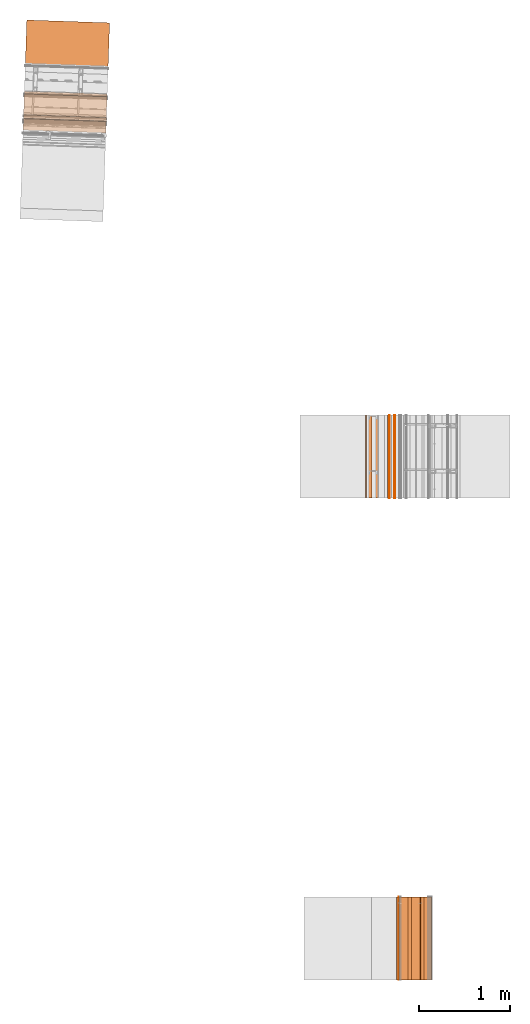
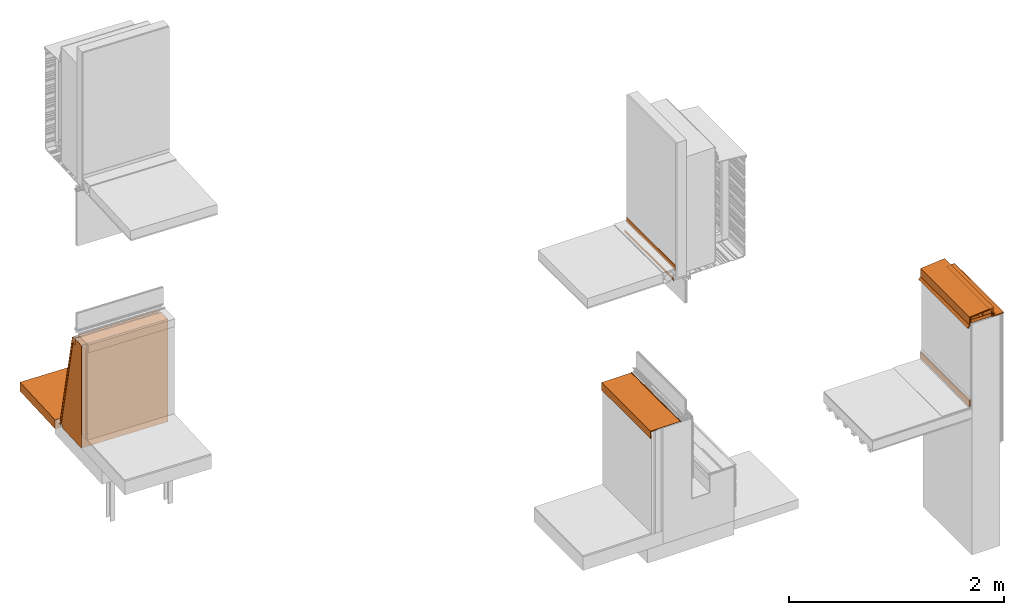
# One storey, part 3 of 36: 18 proxies.
"""IFC2X3 building model written with IfcOpenShell, lengths in feet."""

from ifc_helpers import new_model, entity, si_unit, converted_unit, derived_unit, direction, frame, frame_2d, origin, origin_2d_with_axis, place, context, subcontext, project, spatial, polyline, circle_curve, parameter, trimmed, segment, composite_curve, rectangle, outline, extrude, source, transform, mapped, material, type_object, type_shapes, element, save


model = new_model("IFC2X3")

# Units and contexts
model_context = context("Model", 3, precision=0.0001, world=origin(), true_north=direction((6.12303176911189e-17, 1.0)))
body_context = subcontext(model_context, "Body", "Model", "MODEL_VIEW")
ifc_project = project(units=[converted_unit("LENGTHUNIT", "FOOT", entity("IfcRatioMeasure", 0.3048), si_unit("LENGTHUNIT", "METRE"), dimensions=[1, 0, 0, 0, 0, 0, 0]), converted_unit("AREAUNIT", "SQUARE FOOT", entity("IfcRatioMeasure", 0.09290304), si_unit("AREAUNIT", "SQUARE_METRE"), dimensions=[2, 0, 0, 0, 0, 0, 0]), converted_unit("VOLUMEUNIT", "CUBIC FOOT", entity("IfcRatioMeasure", 0.028316846592), si_unit("VOLUMEUNIT", "CUBIC_METRE"), dimensions=[3, 0, 0, 0, 0, 0, 0]), converted_unit("PLANEANGLEUNIT", "DEGREE", entity("IfcRatioMeasure", 0.0174532925199433), si_unit("PLANEANGLEUNIT", "RADIAN"), dimensions=[0, 0, 0, 0, 0, 0, 0]), si_unit("MASSUNIT", "GRAM", prefix="KILO"), derived_unit("MASSDENSITYUNIT", [(si_unit("MASSUNIT", "GRAM", prefix="KILO"), 1), (si_unit("LENGTHUNIT", "METRE"), -3)]), si_unit("TIMEUNIT", "SECOND"), si_unit("FREQUENCYUNIT", "HERTZ"), si_unit("THERMODYNAMICTEMPERATUREUNIT", "DEGREE_CELSIUS"), derived_unit("THERMALTRANSMITTANCEUNIT", [(si_unit("MASSUNIT", "GRAM", prefix="KILO"), 1), (si_unit("THERMODYNAMICTEMPERATUREUNIT", "KELVIN"), -1), (si_unit("TIMEUNIT", "SECOND"), -3)]), derived_unit("VOLUMETRICFLOWRATEUNIT", [(si_unit("LENGTHUNIT", "METRE"), 3), (si_unit("TIMEUNIT", "SECOND"), -1)]), si_unit("ELECTRICCURRENTUNIT", "AMPERE"), si_unit("ELECTRICVOLTAGEUNIT", "VOLT"), si_unit("POWERUNIT", "WATT"), si_unit("FORCEUNIT", "NEWTON"), si_unit("ILLUMINANCEUNIT", "LUX"), si_unit("LUMINOUSFLUXUNIT", "LUMEN"), si_unit("LUMINOUSINTENSITYUNIT", "CANDELA"), derived_unit("USERDEFINED", [(si_unit("MASSUNIT", "GRAM", prefix="KILO"), -1), (si_unit("LENGTHUNIT", "METRE"), -2), (si_unit("TIMEUNIT", "SECOND"), 3), (si_unit("LUMINOUSFLUXUNIT", "LUMEN"), 1)]), derived_unit("LINEARVELOCITYUNIT", [(si_unit("LENGTHUNIT", "METRE"), 1), (si_unit("TIMEUNIT", "SECOND"), -1)]), si_unit("PRESSUREUNIT", "PASCAL"), derived_unit("USERDEFINED", [(si_unit("LENGTHUNIT", "METRE"), -2), (si_unit("MASSUNIT", "GRAM", prefix="KILO"), 1), (si_unit("TIMEUNIT", "SECOND"), -2)])], contexts=[model_context])

# Site, building, storey
site_placement = place(None, origin())
site = spatial("IfcSite", under=ifc_project, at=site_placement, CompositionType="ELEMENT")
building_placement = place(site_placement, origin())
building = spatial("IfcBuilding", under=site, at=building_placement, CompositionType="ELEMENT")
storey_placement = place(building_placement, origin())
storey = spatial("IfcBuildingStorey", under=building, at=storey_placement, Name="Level 1", CompositionType="ELEMENT", Elevation=0.0)

# Proxies
ifc_material_1 = material(Name="_EXISTING CAST-IN-PLACE CONCRETE")
building_element_proxy_type_1 = type_object("IfcBuildingElementProxyType", PredefinedType="NOTDEFINED", material=ifc_material_1)
shared_shape_1 = source(origin(), body_context, "Body", "SweptSolid", [
    extrude(rectangle(XDim=0.726514148720483, YDim=2.99999999999999, at=frame_2d((7.105427357601e-15, 7.105427357601e-15), x_axis=(1.0, 0.0))), frame((123.703824125935, -80.1652000961286, 18.5413868705315)), (0.0, 0.0, 1.0), 0.125),
])
type_shapes(building_element_proxy_type_1, [shared_shape_1])
proxy_1_placement = place(storey_placement, origin())
element("IfcBuildingElementProxy", 1, at=proxy_1_placement, inside=storey, type_object=building_element_proxy_type_1, material=ifc_material_1, context=body_context, shape_type="MappedRepresentation", body=[
    mapped(shared_shape_1, transform((0.0, 0.0, 0.0), scale=1.0)),
])
ifc_material_2 = material()
building_element_proxy_type_2 = type_object("IfcBuildingElementProxyType", PredefinedType="NOTDEFINED", material=ifc_material_2)
shared_shape_2 = source(origin(), body_context, "Body", "SweptSolid", [
    extrude(outline(composite_curve([segment(polyline([(-0.126157407405415, -0.0601851851839292), (-0.126157407400868, 0.148148148147087)]), True, "CONTINUOUS"), segment(trimmed(circle_curve(frame_2d((-0.136574074067539, 0.148148148147087), x_axis=(1.0, 0.0)), 0.0104166666666667), [parameter(0.0)], [parameter(90.0000000000001)], True, "PARAMETER"), True, "CONTINUOUS"), segment(polyline([(-0.136574074067539, 0.158564814815087), (-0.146990740738744, 0.158564814815087)]), True, "CONTINUOUS"), segment(polyline([(-0.146990740738744, 0.158564814815087), (-0.146990740738744, -0.0914351851849098)]), True, "CONTINUOUS"), segment(polyline([(-0.146990740738744, -0.0914351851849098), (0.269675925927928, -0.0914351851849098)]), True, "CONTINUOUS"), segment(polyline([(0.269675925927928, -0.0914351851849098), (0.269675925922996, -0.081018518519123)]), True, "CONTINUOUS"), segment(trimmed(circle_curve(frame_2d((0.259259259256325, -0.081018518519123), x_axis=(1.0, 0.0)), 0.0104166666666667), [parameter(0.0)], [parameter(90.0000000000001)], True, "PARAMETER"), True, "CONTINUOUS"), segment(polyline([(0.259259259256325, -0.0706018518515741), (-0.115740740747256, -0.0706018518505971)]), True, "CONTINUOUS"), segment(trimmed(circle_curve(frame_2d((-0.115740740747256, -0.0601851851839292), x_axis=(1.0, 0.0)), 0.0104166666666667), [parameter(180.0)], [parameter(270.0)], True, "PARAMETER"), False, "CONTINUOUS")], self_intersect=False)), frame((124.236045845562, -81.6735334294619, 18.6254931215366), z_axis=(0.0, -1.0, 0.0), x_axis=(1.0, 0.0, 0.0)), (0.0, 0.0, -1.0), 3.00833333333334),
])
type_shapes(building_element_proxy_type_2, [shared_shape_2])
proxy_2_placement = place(storey_placement, origin())
element("IfcBuildingElementProxy", 2, at=proxy_2_placement, inside=storey, type_object=building_element_proxy_type_2, material=ifc_material_2, context=body_context, shape_type="MappedRepresentation", body=[
    mapped(shared_shape_2, transform((0.0, 0.0, 0.0), scale=1.0)),
])
ifc_material_3 = material(Name="SHEET METAL COPING")
building_element_proxy_type_3 = type_object("IfcBuildingElementProxyType", PredefinedType="NOTDEFINED", material=ifc_material_3)
shared_shape_3 = source(origin(), body_context, "Body", "SweptSolid", [
    extrude(outline(polyline([(-0.384540585007616, -0.18030977257429), (0.420447563981819, -0.18030977257429), (0.405015562693536, -0.0039211907162079), (0.450069128128935, 0.0497715577507781), (0.446079313319709, 0.0531194098856544), (0.399639022126757, -0.0022259739848406), (0.41476366553856, -0.175101439239162), (-0.379768026807792, -0.175101439243266), (-0.406113571382451, 0.126029513184232), (-0.475565080766948, 0.184306249093279), (-0.478912932901812, 0.180316434284072), (-0.411114058922567, 0.123426424134038), (-0.384540585007616, -0.18030977257429)])), frame((123.718526042381, -81.6652000961286, 18.6189985999881), z_axis=(0.0, 1.0, 0.0), x_axis=(0.996194698091605, 0.0, 0.0871557427492606)), (0.0, 0.0, 1.0), 2.99999999999999),
])
type_shapes(building_element_proxy_type_3, [shared_shape_3])
proxy_3_placement = place(storey_placement, origin())
element("IfcBuildingElementProxy", 3, at=proxy_3_placement, inside=storey, type_object=building_element_proxy_type_3, material=ifc_material_3, context=body_context, shape_type="MappedRepresentation", body=[
    mapped(shared_shape_3, transform((0.0, 0.0, 0.0), scale=1.0)),
])
building_element_proxy_type_4 = type_object("IfcBuildingElementProxyType", PredefinedType="NOTDEFINED", material=ifc_material_3)
shared_shape_4 = source(origin(), body_context, "Body", "SweptSolid", [
    extrude(outline(polyline([(0.349357984822524, -0.284846178640801), (0.346069286579252, -0.247256185651949), (0.340880772538797, -0.247710121810309), (0.344585426635241, -0.290054511964105), (0.397843137388855, -0.290054511984151), (0.390239316204433, -0.203142438006252), (0.511402764102538, -0.0587454637233541), (-0.187119219180262, 0.432176288364868), (-0.385321837412639, 0.195967606091547), (-0.492572986163601, 0.186584346440728), (-0.483324881741879, 0.134135739985906), (-0.438985584190289, 0.138014925864159), (-0.439439520350668, 0.143203439927715), (-0.479024420737317, 0.139740209902621), (-0.486456780502818, 0.181891216776797), (-0.382718748365592, 0.190967118550762), (-0.186202501804319, 0.425166061327164), (0.503765777611596, -0.0597441415342181), (0.384862775629461, -0.201447221276654), (0.392159238937025, -0.284846178640801), (0.349357984822524, -0.284846178640801)])), frame((123.717808814436, -81.6652000961286, 18.5726935719849), z_axis=(0.0, -1.0, 0.0), x_axis=(0.766044443029612, 0.0, 0.642787609793041)), (0.0, 0.0, -1.0), 3.0),
])
type_shapes(building_element_proxy_type_4, [shared_shape_4])
proxy_4_placement = place(storey_placement, origin())
element("IfcBuildingElementProxy", 4, at=proxy_4_placement, inside=storey, type_object=building_element_proxy_type_4, material=ifc_material_3, context=body_context, shape_type="MappedRepresentation", body=[
    mapped(shared_shape_4, transform((0.0, 0.0, 0.0), scale=1.0)),
])
ifc_material_4 = material(Name="SET IN BED OF SEALANT")
building_element_proxy_type_5 = type_object("IfcBuildingElementProxyType", PredefinedType="NOTDEFINED", material=ifc_material_4)
shared_shape_5 = source(origin(), body_context, "Body", "SweptSolid", [
    extrude(rectangle(XDim=0.268491979291795, YDim=3.00833333333563, at=frame_2d((-7.105427357601e-15, 0.0), x_axis=(1.0, 0.0))), frame((124.349787952059, -80.1693667627964, 18.5172838741273), z_axis=(0.0, 0.0, 1.0), x_axis=(-1.0, 0.0, 0.0)), (0.0, 0.0, 1.0), 0.0156250000000036),
])
type_shapes(building_element_proxy_type_5, [shared_shape_5])
proxy_5_placement = place(storey_placement, origin())
element("IfcBuildingElementProxy", 5, at=proxy_5_placement, inside=storey, type_object=building_element_proxy_type_5, material=ifc_material_4, context=body_context, shape_type="MappedRepresentation", body=[
    mapped(shared_shape_5, transform((0.0, 0.0, 0.0), scale=1.0)),
])
building_element_proxy_type_6 = type_object("IfcBuildingElementProxyType", PredefinedType="NOTDEFINED", material=ifc_material_2)
shared_shape_6 = source(origin(), body_context, "Body", "SweptSolid", [
    extrude(outline(polyline([(-0.132931500054667, -0.164930555555557), (-0.127723166721339, -0.164930555555557), (-0.127723166721339, 0.0798611111111036), (0.260654666776034, 0.0798611111111036), (0.260654666776034, 0.0850694444444429), (-0.132931500054667, 0.0850694444444429), (-0.132931500054667, -0.164930555555557)])), frame((124.215067713604, -81.6735334294619, 18.6043959895199), z_axis=(0.0, 1.0, 0.0), x_axis=(1.0, 0.0, 0.0)), (0.0, 0.0, 1.0), 3.00833333333334),
])
type_shapes(building_element_proxy_type_6, [shared_shape_6])
proxy_6_placement = place(storey_placement, origin())
element("IfcBuildingElementProxy", 6, at=proxy_6_placement, inside=storey, type_object=building_element_proxy_type_6, material=ifc_material_2, context=body_context, shape_type="MappedRepresentation", body=[
    mapped(shared_shape_6, transform((0.0, 0.0, 0.0), scale=1.0)),
])
building_element_proxy_type_7 = type_object("IfcBuildingElementProxyType", PredefinedType="NOTDEFINED", material=ifc_material_1)
shared_shape_7 = source(origin(), body_context, "Body", "SweptSolid", [
    extrude(outline(polyline([(-0.143116286141924, -0.06489382711281), (0.154471234553299, -0.0648938271128099), (0.141986030363002, 0.0778127097802322), (-0.153340978774378, 0.0519749444453948), (-0.143116286141924, -0.06489382711281)])), frame((123.918853645128, -81.6652000961286, 18.7315285815215), z_axis=(0.0, 1.0, 0.0), x_axis=(0.996194698091072, 0.0, 0.0871557427553567)), (0.0, 0.0, 1.0), 3.0),
])
type_shapes(building_element_proxy_type_7, [shared_shape_7])
proxy_7_placement = place(storey_placement, origin())
element("IfcBuildingElementProxy", 7, at=proxy_7_placement, inside=storey, type_object=building_element_proxy_type_7, material=ifc_material_1, context=body_context, shape_type="MappedRepresentation", body=[
    mapped(shared_shape_7, transform((0.0, 0.0, 0.0), scale=1.0)),
])
building_element_proxy_type_8 = type_object("IfcBuildingElementProxyType", PredefinedType="NOTDEFINED", material=ifc_material_1)
shared_shape_8 = source(origin(), body_context, "Body", "SweptSolid", [
    extrude(outline(polyline([(-0.142361676977426, -0.0460484345638325), (0.150419108972878, -0.0460484345638325), (0.141249677473897, 0.0587586470487527), (-0.149307109469378, 0.0333382220789169), (-0.142361676977426, -0.0460484345638325)])), frame((123.486400384908, -81.6652000961286, 18.7126112026345), z_axis=(0.0, 1.0, 0.0), x_axis=(0.996194698091215, 0.0, 0.0871557427537215)), (0.0, 0.0, 1.0), 3.0),
])
type_shapes(building_element_proxy_type_8, [shared_shape_8])
proxy_8_placement = place(storey_placement, origin())
element("IfcBuildingElementProxy", 8, at=proxy_8_placement, inside=storey, type_object=building_element_proxy_type_8, material=ifc_material_1, context=body_context, shape_type="MappedRepresentation", body=[
    mapped(shared_shape_8, transform((0.0, 0.0, 0.0), scale=1.0)),
])
building_element_proxy_type_9 = type_object("IfcBuildingElementProxyType", PredefinedType="NOTDEFINED", material=ifc_material_2)
shared_shape_9 = source(origin(), body_context, "Body", "SweptSolid", [
    extrude(rectangle(XDim=0.0284419906168267, YDim=2.99999999999999, at=frame_2d((-7.105427357601e-15, 7.105427357601e-15), x_axis=(1.0, 0.0))), frame((123.317486300394, -80.1652000961286, 15.4316627473064)), (0.0, 0.0, 1.0), 0.244875002274938),
])
type_shapes(building_element_proxy_type_9, [shared_shape_9])
proxy_9_placement = place(storey_placement, origin())
element("IfcBuildingElementProxy", 9, at=proxy_9_placement, inside=storey, type_object=building_element_proxy_type_9, material=ifc_material_2, context=body_context, shape_type="MappedRepresentation", body=[
    mapped(shared_shape_9, transform((0.0, 0.0, 0.0), scale=1.0)),
])
ifc_material_5 = material(Name="Metallic support for window frame")
building_element_proxy_type_10 = type_object("IfcBuildingElementProxyType", Name="4mm panel 003", PredefinedType="NOTDEFINED", material=ifc_material_5)
shared_shape_10 = source(origin(), body_context, "Body", "SweptSolid", [
    extrude(outline(composite_curve([segment(polyline([(1.85994368621129, 0.344894990095364), (1.87297127371129, 0.344894990095364)]), True, "CONTINUOUS"), segment(polyline([(1.87297127371129, 0.344894990095364), (1.87297127371113, 0.42059426339095)]), True, "CONTINUOUS"), segment(trimmed(circle_curve(frame_2d((1.86640959391604, 0.420594263391327), x_axis=(0.0, -1.0)), 0.00656167979509068), [parameter(89.9999999967095)], [parameter(192.264773728537)], True, "PARAMETER"), True, "CONTINUOUS"), segment(polyline([(1.86501569861095, 0.427006181794418), (-1.86569078189981, -0.384016966135989)]), True, "CONTINUOUS"), segment(trimmed(circle_curve(frame_2d((-1.86403204648516, -0.39164714904306), x_axis=(0.0, -1.0)), 0.00780839896374944), [parameter(192.264773728433)], [parameter(270.000000002817)], True, "PARAMETER"), True, "CONTINUOUS"), segment(polyline([(-1.87184044544881, -0.391647149043444), (-1.87184044544881, -0.467060027424332)]), True, "CONTINUOUS"), segment(polyline([(-1.87184044544881, -0.467060027424332), (-1.86048627878215, -0.467060027424332)]), True, "CONTINUOUS"), segment(polyline([(-1.86048627878215, -0.467060027424332), (-1.86048627878215, -0.406046700980755)]), True, "CONTINUOUS"), segment(polyline([(-1.86048627878215, -0.406046700980755), (-1.86526541795538, -0.401267562430892)]), True, "CONTINUOUS"), segment(polyline([(-1.86526541795538, -0.401267562430892), (-1.86526541795538, -0.395018212430883)]), True, "CONTINUOUS"), segment(polyline([(-1.86526541795538, -0.395018212430883), (-1.8673416913354, -0.39294193819784)]), True, "CONTINUOUS"), segment(trimmed(circle_curve(frame_2d((-1.86498779947423, -0.390579339756305), x_axis=(0.0, -1.0)), 0.00333506795856283), [parameter(134.894269642707)], [parameter(315.10576715111)], True, "PARAMETER"), False, "CONTINUOUS"), segment(polyline([(-1.86262520254494, -0.388225446378058), (-1.86054892710892, -0.390301721584425)]), True, "CONTINUOUS"), segment(polyline([(-1.86054892710892, -0.390301721584425), (-1.85429957710892, -0.390301721584425)]), True, "CONTINUOUS"), segment(polyline([(-1.85429957710892, -0.390301721584425), (-1.85195379039632, -0.39264750832983)]), True, "CONTINUOUS"), segment(polyline([(-1.85195379039632, -0.39264750832983), (1.84470863998426, 0.410974759157047)]), True, "CONTINUOUS"), segment(polyline([(1.84470863998426, 0.410974759157047), (1.85542365038452, 0.42168977093526)]), True, "CONTINUOUS"), segment(polyline([(1.85542365038452, 0.42168977093526), (1.86167300120473, 0.42168977093526)]), True, "CONTINUOUS"), segment(polyline([(1.86167300120473, 0.42168977093526), (1.86374893591603, 0.423765705667069)]), True, "CONTINUOUS"), segment(trimmed(circle_curve(frame_2d((1.86610718107439, 0.421407460471822), x_axis=(0.0, -1.0)), 0.00333506231270377), [parameter(45.0000031642995)], [parameter(224.999999551942)], True, "PARAMETER"), False, "CONTINUOUS"), segment(polyline([(1.86846542635962, 0.419049215447071), (1.86638949123098, 0.416973280088794)]), True, "CONTINUOUS"), segment(polyline([(1.86638949123098, 0.416973280088794), (1.86638949123098, 0.4107239300888)]), True, "CONTINUOUS"), segment(polyline([(1.86638949123098, 0.4107239300888), (1.85994368621129, 0.404278124248911)]), True, "CONTINUOUS"), segment(polyline([(1.85994368621129, 0.404278124248911), (1.85994368621129, 0.344894990095364)]), True, "CONTINUOUS")], self_intersect=False)), frame((109.739448408887, -49.9292797637833, 1.91465955455119), z_axis=(0.999414947916634, -0.034201781836498, 0.0), x_axis=(0.0, 0.0, -1.0)), (0.0, 0.0, 1.0), 3.0),
])
type_shapes(building_element_proxy_type_10, [shared_shape_10])
proxy_10_placement = place(storey_placement, origin())
element("IfcBuildingElementProxy", 10, at=proxy_10_placement, inside=storey, type_object=building_element_proxy_type_10, material=ifc_material_5, Name="4mm panel 003:4mm panel 003", ObjectType="4mm panel 003", context=body_context, shape_type="MappedRepresentation", body=[
    mapped(shared_shape_10, transform((0.0, 0.0, 0.0), scale=1.0)),
])
building_element_proxy_type_11 = type_object("IfcBuildingElementProxyType", Name="Base concrete wall001", PredefinedType="NOTDEFINED", material=ifc_material_1)
shared_shape_11 = source(origin(), body_context, "Body", "SweptSolid", [
    extrude(outline(polyline([(-0.641303666432915, -1.88570835416667), (0.579642022740307, -1.88570835416667), (0.579642022740307, -1.76470827083333), (0.655156100824307, -1.76470827083333), (-0.0986482288672912, 1.70279164583333), (-0.216592292285947, 1.70279164583333), (-0.216592292285947, 1.94762497916667), (-0.641303666432915, 1.94762497916667), (-0.641303666432915, -1.88570835416667)])), frame((109.727855108361, -50.2680491851416, 1.88570835416667), z_axis=(0.999414947916632, -0.0342017818365609, 0.0), x_axis=(0.0342017818365609, 0.999414947916632, 0.0)), (0.0, 0.0, 1.0), 3.00000000000001),
])
type_shapes(building_element_proxy_type_11, [shared_shape_11])
proxy_11_placement = place(storey_placement, origin())
element("IfcBuildingElementProxy", 11, at=proxy_11_placement, inside=storey, type_object=building_element_proxy_type_11, material=ifc_material_1, Name="Base concrete wall001:Base concrete wall001", ObjectType="Base concrete wall001", context=body_context, shape_type="MappedRepresentation", body=[
    mapped(shared_shape_11, transform((0.0, 0.0, 0.0), scale=1.0)),
])
building_element_proxy_type_12 = type_object("IfcBuildingElementProxyType", Name="Sidewalk pavement001", PredefinedType="NOTDEFINED", material=ifc_material_1)
shared_shape_12 = source(origin(), body_context, "Body", "SweptSolid", [
    extrude(rectangle(XDim=3.00000000000001, YDim=2.28466369050525, at=origin_2d_with_axis()), frame((111.302316023683, -48.1178754300121, -0.333333333333324), z_axis=(0.0, 0.0, 1.0), x_axis=(0.999414947916632, -0.0342017818365576, 0.0)), (0.0, 0.0, 1.0), 0.333333333333324),
])
type_shapes(building_element_proxy_type_12, [shared_shape_12])
proxy_12_placement = place(storey_placement, origin())
element("IfcBuildingElementProxy", 12, at=proxy_12_placement, inside=storey, type_object=building_element_proxy_type_12, material=ifc_material_1, Name="Sidewalk pavement001:Sidewalk pavement001", ObjectType="Sidewalk pavement001", context=body_context, shape_type="MappedRepresentation", body=[
    mapped(shared_shape_12, transform((0.0, 0.0, 0.0), scale=1.0)),
])
ifc_material_6 = material()
building_element_proxy_type_13 = type_object("IfcBuildingElementProxyType", Name="WRB Membrane 006", PredefinedType="NOTDEFINED", material=ifc_material_6)
shared_shape_13 = source(origin(), body_context, "Body", "SweptSolid", [
    extrude(outline(polyline([(0.815160691691273, 0.247067375582346), (1.04687066544455, 0.247067375582346), (1.04687066544455, 0.260190735162402), (0.80203733211122, 0.260190735162402), (0.802037332111221, 0.129123312163706), (-2.66546258455545, -0.62468101752789), (-2.66267479393865, -0.637504854338901), (0.815160691691273, 0.118546338213578), (0.815160691691273, 0.247067375582346)])), frame((109.728897410511, -50.2375919313563, 2.78646266788879), z_axis=(0.999414947916644, -0.0342017818362211, 0.0), x_axis=(0.0, 0.0, 1.0)), (0.0, 0.0, 1.0), 3.0),
])
type_shapes(building_element_proxy_type_13, [shared_shape_13])
proxy_13_placement = place(storey_placement, origin())
element("IfcBuildingElementProxy", 13, at=proxy_13_placement, inside=storey, type_object=building_element_proxy_type_13, material=ifc_material_6, Name="Membrane 006:Membrane 006", ObjectType="WRB Membrane 006", context=body_context, shape_type="MappedRepresentation", body=[
    mapped(shared_shape_13, transform((0.0, 0.0, 0.0), scale=1.0)),
])
building_element_proxy_type_14 = type_object("IfcBuildingElementProxyType", Name="Corner piece 003", PredefinedType="NOTDEFINED", material=ifc_material_5)
shared_shape_14 = source(origin(), body_context, "Body", "SweptSolid", [
    extrude(outline(polyline([(-0.0729575182633422, -0.140467365704268), (-0.0632016241360454, -0.140467365704268), (-0.0632016241360454, 0.0660140870516273), (0.136159142399388, 0.0660140870516273), (0.136159142399388, 0.0744532786526833), (-0.0729575182633422, 0.0744532786526833), (-0.0729575182633422, -0.140467365704268)])), frame((122.191925036678, -64.2284331589239, 4.27200617734236), z_axis=(0.0, 1.0, 0.0), x_axis=(0.0, 0.0, -1.0)), (0.0, 0.0, 1.0), 3.0),
])
type_shapes(building_element_proxy_type_14, [shared_shape_14])
proxy_14_placement = place(storey_placement, origin())
element("IfcBuildingElementProxy", 14, at=proxy_14_placement, inside=storey, type_object=building_element_proxy_type_14, material=ifc_material_5, Name="Corner piece 003:Corner piece 003", ObjectType="Corner piece 003", context=body_context, shape_type="MappedRepresentation", body=[
    mapped(shared_shape_14, transform((0.0, 0.0, 0.0), scale=1.0)),
])
building_element_proxy_type_15 = type_object("IfcBuildingElementProxyType", Name="Aluminium profile 010", PredefinedType="NOTDEFINED", material=ifc_material_5)
shared_shape_15 = source(origin(), body_context, "Body", "SweptSolid", [
    extrude(outline(polyline([(-0.12890770544022, -0.700647282288926), (-0.098232733506781, -0.700647282288926), (-0.098232733506781, -0.691355841180027), (-0.119609856440877, -0.691355841180027), (-0.119609856440877, 0.352220376667745), (0.147723138248277, 0.352220376667745), (0.147723138248277, 0.343781185066717), (0.0420061699739991, 0.343781185066717), (0.0420061699739991, 0.334483336149376), (0.1570209871656, 0.334483336149376), (0.1570209871656, 0.361518225585087), (-0.12890770544022, 0.361518225585087), (-0.12890770544022, -0.700647282288926)])), frame((122.469692134529, -64.2284331589238, 4.23943689937238), z_axis=(0.0, 1.0, 0.0), x_axis=(0.0, 0.0, -1.0)), (0.0, 0.0, 1.0), 3.0),
])
type_shapes(building_element_proxy_type_15, [shared_shape_15])
proxy_15_placement = place(storey_placement, origin())
element("IfcBuildingElementProxy", 15, at=proxy_15_placement, inside=storey, type_object=building_element_proxy_type_15, material=ifc_material_5, Name="Aluminium profile 010:Aluminium profile 010", ObjectType="Aluminium profile 010", context=body_context, shape_type="MappedRepresentation", body=[
    mapped(shared_shape_15, transform((0.0, 0.0, 0.0), scale=1.0)),
])
building_element_proxy_type_16 = type_object("IfcBuildingElementProxyType", Name="Sealant 010", PredefinedType="NOTDEFINED", material=ifc_material_2)
shared_shape_16 = source(origin(), body_context, "Body", "SweptSolid", [
    extrude(outline(composite_curve([segment(trimmed(circle_curve(frame_2d((-0.00922095399957357, 0.0), x_axis=(1.0, 0.0)), 0.00445989173228297), [parameter(90.0000000000001)], [parameter(270.0)], True, "PARAMETER"), True, "CONTINUOUS"), segment(polyline([(-0.00922095399957357, -0.00445989173226558), (0.00922095399958778, -0.00445989173228867)]), True, "CONTINUOUS"), segment(trimmed(circle_curve(frame_2d((0.00922095399958778, 0.0), x_axis=(1.0, 0.0)), 0.00445989173228297), [parameter(270.0)], [parameter(90.0000000000001)], True, "PARAMETER"), True, "CONTINUOUS"), segment(polyline([(0.00922095399958778, 0.00445989173227712), (-0.00922095399957357, 0.00445989173227801)]), True, "CONTINUOUS")], self_intersect=False)), frame((123.163040830768, -64.2284331589239, 4.37454023222194), z_axis=(0.0, 1.0, 0.0), x_axis=(1.0, 0.0, 0.0)), (0.0, 0.0, 1.0), 3.0),
])
type_shapes(building_element_proxy_type_16, [shared_shape_16])
proxy_16_placement = place(storey_placement, origin())
element("IfcBuildingElementProxy", 16, at=proxy_16_placement, inside=storey, type_object=building_element_proxy_type_16, material=ifc_material_2, Name="Sealant 010:Sealant 010", ObjectType="Sealant 010", context=body_context, shape_type="MappedRepresentation", body=[
    mapped(shared_shape_16, transform((0.0, 0.0, 0.0), scale=1.0)),
])
building_element_proxy_type_17 = type_object("IfcBuildingElementProxyType", Name="Shade pocket part 013", PredefinedType="NOTDEFINED", material=ifc_material_1)
shared_shape_17 = source(origin(), body_context, "Body", "SweptSolid", [
    extrude(outline(polyline([(0.026534653614882, -0.0208243061174755), (0.0248895271764063, -0.0244817625209915), (0.039899876878973, -0.0256790643807462), (0.0445239017282928, -0.0158381919453044), (0.0304999176550857, -0.00174010345341065), (-0.0195509479077139, 0.0217777754349319), (-0.0419806514003922, 0.0249875609724697), (-0.0454426492510573, 0.0176197201129682), (-0.0325016482055936, 0.00313104637150579), (-0.0306953882108853, 0.00697513777940145), (-0.0402419428352611, 0.017984194689895), (-0.0391013498926071, 0.0204116102023948), (-0.0201526799102565, 0.0175066871723256), (0.0273090303814406, -0.00479460056610967), (0.0390889308025545, -0.0162113976347576), (0.0369214193759349, -0.0208243061174755), (0.026534653614882, -0.0208243061174755)])), frame((122.922988681224, -64.228432568631, 9.74169645560941), z_axis=(0.0, -1.0, 0.0), x_axis=(-0.425271857311963, 0.0, 0.90506565915321)), (0.0, 0.0, -1.0), 2.99999999999999),
])
type_shapes(building_element_proxy_type_17, [shared_shape_17])
proxy_17_placement = place(storey_placement, origin())
element("IfcBuildingElementProxy", 17, at=proxy_17_placement, inside=storey, type_object=building_element_proxy_type_17, material=ifc_material_1, Name="Shade pocket part 013:Shade pocket part 013", ObjectType="Shade pocket part 013", context=body_context, shape_type="MappedRepresentation", body=[
    mapped(shared_shape_17, transform((0.0, 0.0, 0.0), scale=1.0)),
])
building_element_proxy_type_18 = type_object("IfcBuildingElementProxyType", Name="Shade pocket part 014", PredefinedType="NOTDEFINED", material=ifc_material_1)
shared_shape_18 = source(origin(), body_context, "Body", "SweptSolid", [
    extrude(outline(polyline([(-0.0678116124999999, -0.00455977383330719), (-0.0678116124999999, -0.0120008413333181), (0.123354006666666, -0.0120008413333181), (0.123354006666666, -0.00461728883331602), (-0.0229502066666658, -0.00461728883331602), (-0.0229502066666658, 0.00719110700001124), (-0.00383732916666624, 0.00719110700001124), (-0.00383732916666624, 0.0139867970000154), (-0.0287548583333326, 0.0139867970000154), (-0.0287548583333326, -0.00455977383330719), (-0.0678116124999999, -0.00455977383330719)])), frame((122.975748869474, -64.2284325353576, 10.1215635223803), z_axis=(0.0, -1.0, 0.0), x_axis=(0.0, 0.0, 1.0)), (0.0, 0.0, -1.0), 2.99999999999999),
])
type_shapes(building_element_proxy_type_18, [shared_shape_18])
proxy_18_placement = place(storey_placement, origin())
element("IfcBuildingElementProxy", 18, at=proxy_18_placement, inside=storey, type_object=building_element_proxy_type_18, material=ifc_material_1, Name="Shade pocket part 014:Shade pocket part 014", ObjectType="Shade pocket part 014", context=body_context, shape_type="MappedRepresentation", body=[
    mapped(shared_shape_18, transform((0.0, 0.0, 0.0), scale=1.0)),
])

save(model, "model.ifc")
